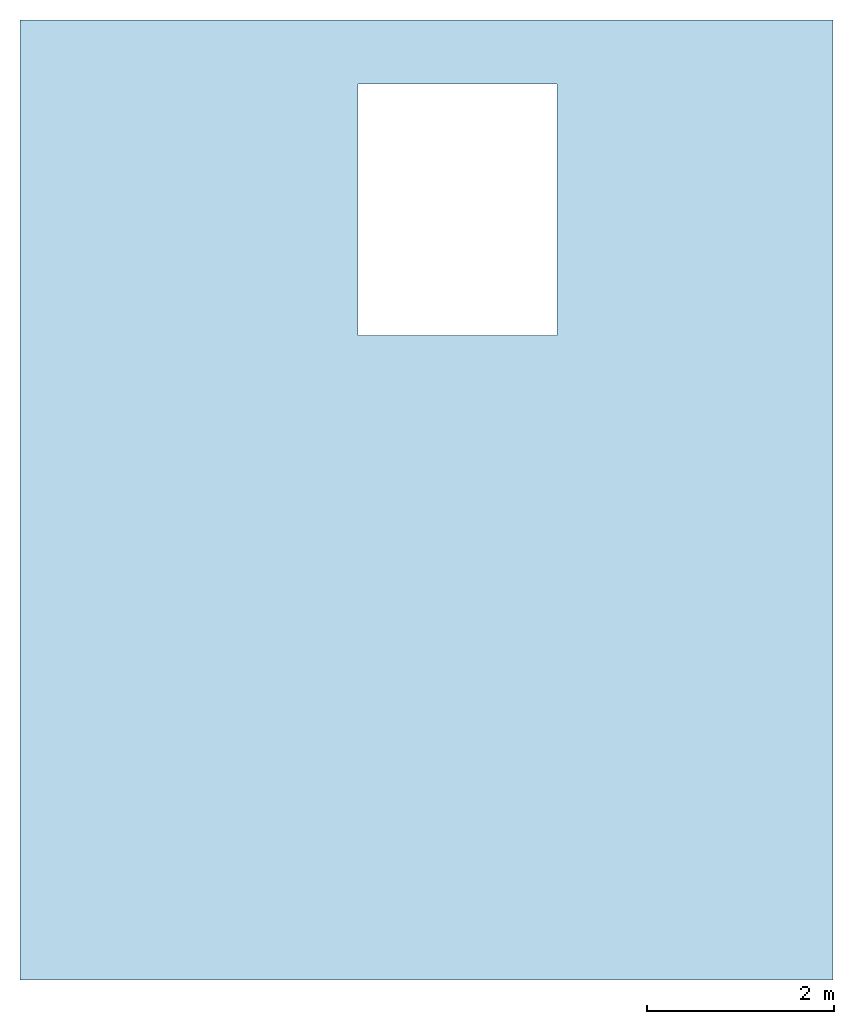
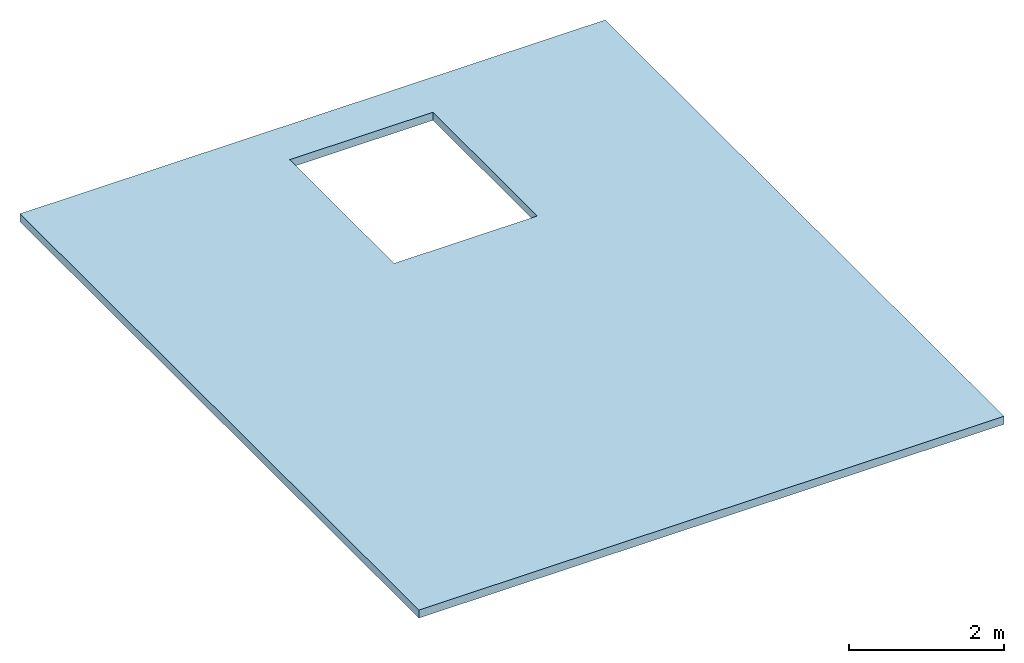
# One storey: 1 slab, 1 opening.
"""IFC2X3 building model written with IfcOpenShell, lengths in feet."""

import ifcopenshell
import ifcopenshell.guid

model = None  # the IFC model being written
_history = None  # IfcOwnerHistory: only IFC2X3 demands one
_inside = {}  # id of a spatial element -> (the spatial element, [elements in it])
_under = {}  # id of a project, library or spatial element -> (it, [spatial elements below it])
_declared = {}  # id of a project -> (the project, [libraries it declares])
_typed = {}  # id of a type object -> (the type object, [elements of that type])
_made_of = {}  # id of a material, layer set ... -> (it, [elements and type objects made of it])


def new_model(schema):
    """Start an empty IFC model of exactly this schema.

    Asked for "IFC4X3", IfcOpenShell would pick the latest addendum, in which some entities
    have other attributes; the version numbers below select the first issue.
    IFC2X3 requires an IfcOwnerHistory on every rooted entity: one is made here for all.
    """
    global model, _history
    if schema == "IFC4X3":
        model = ifcopenshell.file(schema_version=(4, 3, 0, 0))
    else:
        model = ifcopenshell.file(schema=schema)
    _inside.clear()
    _under.clear()
    _declared.clear()
    _typed.clear()
    _made_of.clear()
    _history = None
    if model.schema == "IFC2X3":
        org = make("IfcOrganization", Name="unknown")
        user = make(
            "IfcPersonAndOrganization",
            ThePerson=make("IfcPerson", FamilyName="unknown"),
            TheOrganization=org,
        )
        app = make(
            "IfcApplication",
            ApplicationDeveloper=org,
            Version="unknown",
            ApplicationFullName="unknown",
            ApplicationIdentifier="unknown",
        )
        _history = make(
            "IfcOwnerHistory",
            OwningUser=user,
            OwningApplication=app,
            ChangeAction="ADDED",
            CreationDate=0,
        )
    return model


def make(cls, **values):
    """One entity of the class cls with the attributes given. An attribute that is None is left unset."""
    return model.create_entity(
        cls, **{name: value for name, value in values.items() if value is not None}
    )


def entity(cls, *values):
    """Any entity or typed value of the class cls, its attributes in the order of the schema. None: left unset."""
    e = model.create_entity(cls)
    for i, value in enumerate(values):
        if value is not None:
            e[i] = value
    return e


def rooted(cls, **values):
    """An entity with a GlobalId (a new one), such as an element, a storey or a relation."""
    return make(cls, GlobalId=ifcopenshell.guid.new(), OwnerHistory=_history, **values)


def si_unit(unit_type, name, prefix=None):
    """IfcSIUnit, for example si_unit("LENGTHUNIT", "METRE", prefix="MILLI")."""
    return make("IfcSIUnit", UnitType=unit_type, Prefix=prefix, Name=name)


def converted_unit(unit_type, name, factor, base, dimensions=None, offset=None):
    """IfcConversionBasedUnit, such as the inch: factor (a typed value) times the base unit."""
    return make(
        "IfcConversionBasedUnit"
        if offset is None
        else "IfcConversionBasedUnitWithOffset",
        ConversionOffset=offset,
        Dimensions=None
        if dimensions is None
        else entity("IfcDimensionalExponents", *dimensions),
        UnitType=unit_type,
        Name=name,
        ConversionFactor=make(
            "IfcMeasureWithUnit", ValueComponent=factor, UnitComponent=base
        ),
    )


def derived_unit(unit_type, elements):
    """IfcDerivedUnit: a product of units, each with its exponent."""
    return make(
        "IfcDerivedUnit",
        Elements=[
            make("IfcDerivedUnitElement", Unit=unit, Exponent=power)
            for unit, power in elements
        ],
        UnitType=unit_type,
    )


def assignment(units):
    """IfcUnitAssignment: the units of a project."""
    return None if units is None else make("IfcUnitAssignment", Units=units)


def point(xyz):
    """IfcCartesianPoint."""
    return None if xyz is None else make("IfcCartesianPoint", Coordinates=xyz)


def direction(xyz):
    """IfcDirection."""
    return None if xyz is None else make("IfcDirection", DirectionRatios=xyz)


def frame(location, z_axis=None, x_axis=None):
    """IfcAxis2Placement3D, a coordinate frame: its origin and axes. An axis left out is left unset."""
    return make(
        "IfcAxis2Placement3D",
        Location=point(location),
        Axis=direction(z_axis),
        RefDirection=direction(x_axis),
    )


def frame_2d(location, x_axis=None):
    """IfcAxis2Placement2D, a coordinate frame in the plane: its origin and x axis."""
    return make(
        "IfcAxis2Placement2D", Location=point(location), RefDirection=direction(x_axis)
    )


def origin():
    """The frame at (0, 0, 0) with its axes left unset."""
    return frame((0.0, 0.0, 0.0))


def origin_2d_with_axis():
    """The frame at (0, 0) in the plane with the x axis (1, 0) written out."""
    return frame_2d((0.0, 0.0), x_axis=(1.0, 0.0))


def place(relative_to, where):
    """IfcLocalPlacement: puts the frame where relative to a parent placement (None: the world)."""
    return make(
        "IfcLocalPlacement", PlacementRelTo=relative_to, RelativePlacement=where
    )


def context(
    kind, dimensions, precision=None, world=None, true_north=None, identifier=None
):
    """IfcGeometricRepresentationContext, for example the 3D "Model" context."""
    return make(
        "IfcGeometricRepresentationContext",
        ContextIdentifier=identifier,
        ContextType=kind,
        CoordinateSpaceDimension=dimensions,
        Precision=precision,
        WorldCoordinateSystem=world,
        TrueNorth=true_north,
    )


def subcontext(parent, identifier, kind, view, scale=None):
    """IfcGeometricRepresentationSubContext, for example "Body" below "Model"."""
    return make(
        "IfcGeometricRepresentationSubContext",
        ContextIdentifier=identifier,
        ContextType=kind,
        ParentContext=parent,
        TargetScale=scale,
        TargetView=view,
    )


def project(units=None, contexts=None):
    """IfcProject with its units and contexts."""
    return rooted(
        "IfcProject",
        Name="project",
        RepresentationContexts=contexts,
        UnitsInContext=assignment(units),
    )


def spatial(cls, under=None, at=None, **own):
    """A site, building, storey or space (cls), placed at a placement, below another one or the project."""
    s = rooted(cls, ObjectPlacement=at, **own)
    if under is not None:
        _under.setdefault(under.id(), (under, []))[1].append(s)
    return s


def profile(cls, at=None, kind="AREA", **sizes):
    """A parametric profile (cls). Its sizes go by their IFC names, for example OverallWidth=200.0."""
    return make(cls, ProfileType=kind, Position=at, **sizes)


def rectangle(**sizes):
    """IfcRectangleProfileDef."""
    return profile("IfcRectangleProfileDef", **sizes)


def extrude(swept, where, along, depth):
    """IfcExtrudedAreaSolid: the profile swept, set in the frame where, extruded along a direction by depth."""
    return make(
        "IfcExtrudedAreaSolid",
        SweptArea=swept,
        Position=where,
        ExtrudedDirection=direction(along),
        Depth=depth,
    )


def shape(context_of_items, identifier, shape_type, items):
    """IfcShapeRepresentation: the items that make up one representation, for example the "Body"."""
    return make(
        "IfcShapeRepresentation",
        ContextOfItems=context_of_items,
        RepresentationIdentifier=identifier,
        RepresentationType=shape_type,
        Items=items,
    )


def material(Name=None, Category=None):
    """IfcMaterial."""
    return make("IfcMaterial", Name=Name, Category=Category)


def layer(
    of_material, thickness, ventilated=None, Name=None, Category=None, Priority=None
):
    """IfcMaterialLayer: one layer of a wall or slab, of a material (None: an air gap)."""
    return make(
        "IfcMaterialLayer",
        Material=of_material,
        LayerThickness=thickness,
        IsVentilated=ventilated,
        Name=Name,
        Category=Category,
        Priority=Priority,
    )


def layer_set(layers, Name=None):
    """IfcMaterialLayerSet."""
    return make("IfcMaterialLayerSet", MaterialLayers=layers, LayerSetName=Name)


def layer_usage(for_layer_set, set_direction, sense, offset, extent=None):
    """IfcMaterialLayerSetUsage: how a layer set lies in its element."""
    return make(
        "IfcMaterialLayerSetUsage",
        ForLayerSet=for_layer_set,
        LayerSetDirection=set_direction,
        DirectionSense=sense,
        OffsetFromReferenceLine=offset,
        ReferenceExtent=extent,
    )


def made_of(thing, what):
    """Note that an element or type object is made of a material, layer set ...; save() writes the relation."""
    if what is not None:
        _made_of.setdefault(what.id(), (what, []))[1].append(thing)
    return thing


def type_object(cls, material=None, **own):
    """A type object (cls), such as IfcWallType, which elements share."""
    return made_of(rooted(cls, **own), material)


def element(
    cls,
    number,
    at=None,
    inside=None,
    cuts=None,
    type_object=None,
    material=None,
    context=None,
    identifier="Body",
    shape_type=None,
    held_by="IfcProductDefinitionShape",
    body=None,
    shapes=None,
    **own,
):
    """One element of the class cls, such as IfcWall. Its Tag is "e" and its number.

    at: its placement. inside: the storey or other place that contains it. cuts: it is an
    opening in that element (IfcRelVoidsElement). A single representation is given by context,
    identifier, shape_type and body (its items); several are given by shapes. held_by: the class
    of the entity that holds the representations. save() writes the other relations.
    """
    e = rooted(cls, Tag="e%d" % number, ObjectPlacement=at, **own)
    if body is not None:
        shapes = [shape(context, identifier, shape_type, body)]
    if shapes is not None:
        e.Representation = make(held_by, Representations=shapes)
    if inside is not None:
        _inside.setdefault(inside.id(), (inside, []))[1].append(e)
    if cuts is not None:
        rooted(
            "IfcRelVoidsElement", RelatingBuildingElement=cuts, RelatedOpeningElement=e
        )
    if type_object is not None:
        _typed.setdefault(type_object.id(), (type_object, []))[1].append(e)
    return made_of(e, material)


def aggregate(whole, parts):
    """IfcRelAggregates: a whole, such as a stair, and the parts it consists of."""
    return rooted("IfcRelAggregates", RelatingObject=whole, RelatedObjects=parts)


def save(model, path):
    """Write the relations noted so far, then the file.

    IfcRelAggregates (storeys below a building ...), IfcRelContainedInSpatialStructure (elements
    in a storey), IfcRelDefinesByType, IfcRelAssociatesMaterial and IfcRelDeclares: one each for
    every whole, place, type object, material and project.
    """
    for whole, parts in _under.values():
        aggregate(whole, parts)
    for where, things in _inside.values():
        rooted(
            "IfcRelContainedInSpatialStructure",
            RelatedElements=things,
            RelatingStructure=where,
        )
    for kind, things in _typed.values():
        rooted("IfcRelDefinesByType", RelatedObjects=things, RelatingType=kind)
    for what, things in _made_of.values():
        rooted("IfcRelAssociatesMaterial", RelatedObjects=things, RelatingMaterial=what)
    for by, libraries in _declared.values():
        rooted("IfcRelDeclares", RelatingContext=by, RelatedDefinitions=libraries)
    model.write(path)


model = new_model("IFC2X3")

# Units and contexts
model_context = context("Model", 3, precision=0.0001, world=origin(), true_north=direction((6.123031769111886e-17, 1.0)))
body_context = subcontext(model_context, "Body", "Model", "MODEL_VIEW")
ifc_project = project(units=[converted_unit("LENGTHUNIT", "FOOT", entity("IfcLengthMeasure", 0.3048), si_unit("LENGTHUNIT", "METRE"), dimensions=[1, 0, 0, 0, 0, 0, 0]), converted_unit("AREAUNIT", "SQUARE FOOT", entity("IfcAreaMeasure", 0.09290304), si_unit("AREAUNIT", "SQUARE_METRE"), dimensions=[2, 0, 0, 0, 0, 0, 0]), converted_unit("VOLUMEUNIT", "CUBIC FOOT", entity("IfcVolumeMeasure", 0.028316846592000004), si_unit("VOLUMEUNIT", "CUBIC_METRE"), dimensions=[3, 0, 0, 0, 0, 0, 0]), converted_unit("PLANEANGLEUNIT", "DEGREE", entity("IfcPlaneAngleMeasure", 0.017453292519943278), si_unit("PLANEANGLEUNIT", "RADIAN"), dimensions=[0, 0, 0, 0, 0, 0, 0]), si_unit("MASSUNIT", "GRAM", prefix="KILO"), derived_unit("MASSDENSITYUNIT", [(si_unit("MASSUNIT", "GRAM", prefix="KILO"), 1), (si_unit("LENGTHUNIT", "METRE"), -3)]), derived_unit("IONCONCENTRATIONUNIT", [(si_unit("MASSUNIT", "GRAM", prefix="KILO"), 1), (si_unit("LENGTHUNIT", "METRE"), -3)]), derived_unit("MOMENTOFINERTIAUNIT", [(si_unit("LENGTHUNIT", "METRE"), 4)]), si_unit("TIMEUNIT", "SECOND"), si_unit("FREQUENCYUNIT", "HERTZ"), si_unit("THERMODYNAMICTEMPERATUREUNIT", "DEGREE_CELSIUS"), derived_unit("THERMALTRANSMITTANCEUNIT", [(si_unit("MASSUNIT", "GRAM", prefix="KILO"), 1), (si_unit("THERMODYNAMICTEMPERATUREUNIT", "KELVIN"), -1), (si_unit("TIMEUNIT", "SECOND"), -3)]), derived_unit("THERMALCONDUCTANCEUNIT", [(si_unit("MASSUNIT", "GRAM", prefix="KILO"), 1), (si_unit("THERMODYNAMICTEMPERATUREUNIT", "KELVIN"), -1), (si_unit("TIMEUNIT", "SECOND"), -3), (si_unit("LENGTHUNIT", "METRE"), 1)]), derived_unit("VOLUMETRICFLOWRATEUNIT", [(si_unit("LENGTHUNIT", "METRE"), 3), (si_unit("TIMEUNIT", "SECOND"), -1)]), derived_unit("MASSFLOWRATEUNIT", [(si_unit("MASSUNIT", "GRAM", prefix="KILO"), 1), (si_unit("TIMEUNIT", "SECOND"), -1)]), derived_unit("ROTATIONALFREQUENCYUNIT", [(si_unit("TIMEUNIT", "SECOND"), -1)]), si_unit("ELECTRICCURRENTUNIT", "AMPERE"), si_unit("ELECTRICVOLTAGEUNIT", "VOLT"), si_unit("POWERUNIT", "WATT"), converted_unit("FORCEUNIT", "KIP", entity("IfcForceMeasure", 2.088543423315013e-05), si_unit("FORCEUNIT", "NEWTON"), dimensions=[1, 1, -2, 0, 0, 0, 0]), si_unit("ILLUMINANCEUNIT", "LUX"), si_unit("LUMINOUSFLUXUNIT", "LUMEN"), si_unit("LUMINOUSINTENSITYUNIT", "CANDELA"), si_unit("ENERGYUNIT", "JOULE"), derived_unit("USERDEFINED", [(si_unit("MASSUNIT", "GRAM", prefix="KILO"), -1), (si_unit("LENGTHUNIT", "METRE"), -2), (si_unit("TIMEUNIT", "SECOND"), 3), (si_unit("LUMINOUSFLUXUNIT", "LUMEN"), 1)]), derived_unit("USERDEFINED", [(si_unit("MASSUNIT", "GRAM", prefix="KILO"), 1), (si_unit("TIMEUNIT", "SECOND"), -3), (si_unit("LENGTHUNIT", "METRE"), 3), (si_unit("ELECTRICCURRENTUNIT", "AMPERE"), -2)]), derived_unit("SOUNDPOWERUNIT", [(si_unit("MASSUNIT", "GRAM", prefix="KILO"), 1), (si_unit("TIMEUNIT", "SECOND"), -3), (si_unit("LENGTHUNIT", "METRE"), 2)]), derived_unit("SOUNDPRESSUREUNIT", [(si_unit("MASSUNIT", "GRAM", prefix="KILO"), 1), (si_unit("LENGTHUNIT", "METRE"), -1), (si_unit("TIMEUNIT", "SECOND"), -2)]), derived_unit("LINEARVELOCITYUNIT", [(si_unit("LENGTHUNIT", "METRE"), 1), (si_unit("TIMEUNIT", "SECOND"), -1)]), si_unit("PRESSUREUNIT", "PASCAL"), derived_unit("USERDEFINED", [(si_unit("MASSUNIT", "GRAM", prefix="KILO"), 1), (si_unit("LENGTHUNIT", "METRE"), -2), (si_unit("TIMEUNIT", "SECOND"), -2)]), derived_unit("LINEARFORCEUNIT", [(si_unit("MASSUNIT", "GRAM", prefix="KILO"), 1), (si_unit("TIMEUNIT", "SECOND"), -2)]), derived_unit("PLANARFORCEUNIT", [(si_unit("MASSUNIT", "GRAM", prefix="KILO"), 1), (si_unit("LENGTHUNIT", "METRE"), -1), (si_unit("TIMEUNIT", "SECOND"), -2)]), derived_unit("SPECIFICHEATCAPACITYUNIT", [(si_unit("THERMODYNAMICTEMPERATUREUNIT", "KELVIN"), -1), (si_unit("LENGTHUNIT", "METRE"), 2), (si_unit("TIMEUNIT", "SECOND"), -2)]), derived_unit("HEATFLUXDENSITYUNIT", [(si_unit("MASSUNIT", "GRAM", prefix="KILO"), 1), (si_unit("TIMEUNIT", "SECOND"), -3)]), derived_unit("HEATINGVALUEUNIT", [(si_unit("LENGTHUNIT", "METRE"), 2), (si_unit("TIMEUNIT", "SECOND"), -2)]), derived_unit("VAPORPERMEABILITYUNIT", [(si_unit("LENGTHUNIT", "METRE"), -1), (si_unit("TIMEUNIT", "SECOND"), 1)]), derived_unit("DYNAMICVISCOSITYUNIT", [(si_unit("MASSUNIT", "GRAM", prefix="KILO"), 1), (si_unit("TIMEUNIT", "SECOND"), -1), (si_unit("LENGTHUNIT", "METRE"), -1)]), derived_unit("THERMALEXPANSIONCOEFFICIENTUNIT", [(si_unit("THERMODYNAMICTEMPERATUREUNIT", "KELVIN"), -1)]), derived_unit("MODULUSOFELASTICITYUNIT", [(si_unit("MASSUNIT", "GRAM", prefix="KILO"), 1), (si_unit("LENGTHUNIT", "METRE"), -1), (si_unit("TIMEUNIT", "SECOND"), -2)]), derived_unit("ISOTHERMALMOISTURECAPACITYUNIT", [(si_unit("LENGTHUNIT", "METRE"), 3), (si_unit("MASSUNIT", "GRAM", prefix="KILO"), -1)]), derived_unit("MOISTUREDIFFUSIVITYUNIT", [(si_unit("TIMEUNIT", "SECOND"), -1), (si_unit("LENGTHUNIT", "METRE"), 2)]), derived_unit("MASSPERLENGTHUNIT", [(si_unit("MASSUNIT", "GRAM", prefix="KILO"), 1), (si_unit("LENGTHUNIT", "METRE"), -1)]), derived_unit("THERMALRESISTANCEUNIT", [(si_unit("MASSUNIT", "GRAM", prefix="KILO"), -1), (si_unit("TIMEUNIT", "SECOND"), 3), (si_unit("THERMODYNAMICTEMPERATUREUNIT", "KELVIN"), 1)]), derived_unit("ACCELERATIONUNIT", [(si_unit("LENGTHUNIT", "METRE"), 1), (si_unit("TIMEUNIT", "SECOND"), -2)]), derived_unit("ANGULARVELOCITYUNIT", [(si_unit("TIMEUNIT", "SECOND"), -1), (si_unit("PLANEANGLEUNIT", "RADIAN"), 1)]), derived_unit("LINEARSTIFFNESSUNIT", [(si_unit("MASSUNIT", "GRAM", prefix="KILO"), 1), (si_unit("TIMEUNIT", "SECOND"), -2)]), derived_unit("WARPINGCONSTANTUNIT", [(si_unit("LENGTHUNIT", "METRE"), 6)]), derived_unit("LINEARMOMENTUNIT", [(si_unit("MASSUNIT", "GRAM", prefix="KILO"), 1), (si_unit("LENGTHUNIT", "METRE"), 1), (si_unit("TIMEUNIT", "SECOND"), -2)]), derived_unit("TORQUEUNIT", [(si_unit("MASSUNIT", "GRAM", prefix="KILO"), 1), (si_unit("LENGTHUNIT", "METRE"), 2), (si_unit("TIMEUNIT", "SECOND"), -2)])], contexts=[model_context])

# Site, building, storey
site_placement = place(None, origin())
site = spatial("IfcSite", under=ifc_project, at=site_placement, CompositionType="ELEMENT")
building_placement = place(site_placement, origin())
building = spatial("IfcBuilding", under=site, at=building_placement, CompositionType="ELEMENT")
storey_placement = place(building_placement, frame((0.0, 0.0, 9.416666666668336)))
storey = spatial("IfcBuildingStorey", under=building, at=storey_placement, Name="Level 2", CompositionType="ELEMENT", Elevation=9.416666666668336)

# Slab, opening
ifc_material = material(Name="Clad - White")
ifc_layer = layer(ifc_material, 0.4166666666666667)
ifc_layer_set = layer_set([ifc_layer])
ifc_layer_usage = layer_usage(ifc_layer_set, "AXIS3", "POSITIVE", 0.0)
slab_type = type_object("IfcSlabType", PredefinedType="FLOOR", material=ifc_layer_set)
slab_placement = place(storey_placement, frame((-18.409913085251162, -15.499419701928364, -0.4166666666666661)))
slab = element("IfcSlab", 1, at=slab_placement, inside=storey, type_object=slab_type, material=ifc_layer_usage, PredefinedType="FLOOR", context=body_context, shape_type="SweptSolid", body=[
    extrude(rectangle(XDim=33.74999999999997, YDim=28.583333333333364, at=frame_2d((0.0, 0.0), x_axis=(0.0, -1.0))), frame((14.291666666666682, 16.874999999999986, 0.4166666666666661), z_axis=(0.0, 0.0, -1.0), x_axis=(-1.0, 0.0, 0.0)), (0.0, 0.0, 1.0), 0.4166666666666661),
])
opening_placement = place(slab_placement, origin())
element("IfcOpeningElement", 2, at=opening_placement, cuts=slab, ObjectType="Opening", context=body_context, shape_type="SweptSolid", body=[
    extrude(rectangle(XDim=8.833333333333307, YDim=6.999999999999997, at=origin_2d_with_axis()), frame((15.375000000000002, 27.083333333333343, 0.4166666666666661), z_axis=(0.0, 0.0, -1.0), x_axis=(0.0, -1.0, 0.0)), (0.0, 0.0, 1.0), 0.4166666666666667),
])

save(model, "model.ifc")
